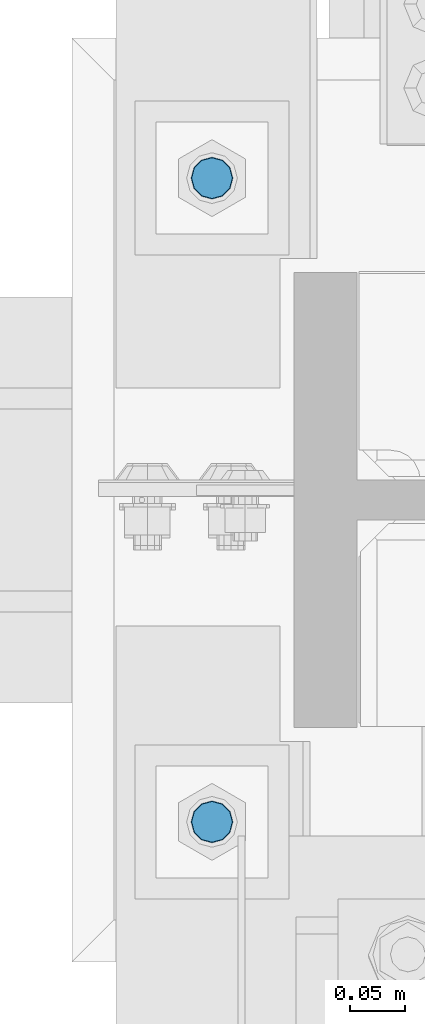
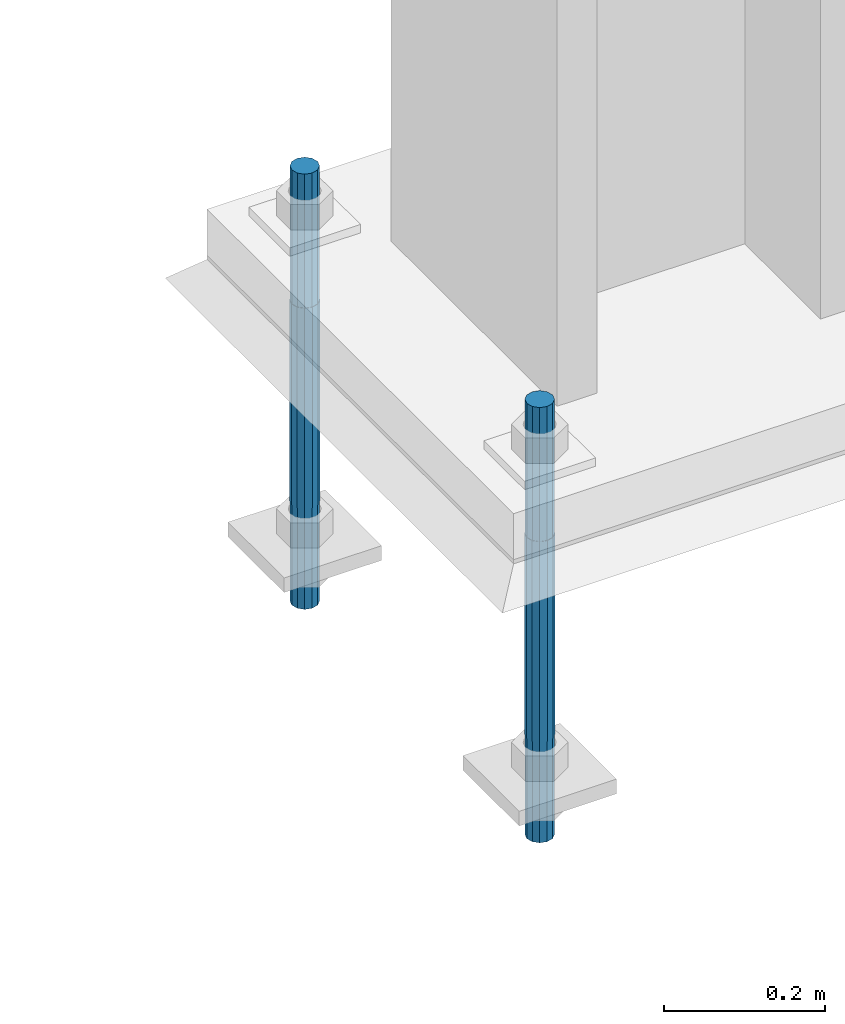
# One storey, part 1639 of 3843: 2 columns, 1 element without a shape of its own.
"""IFC2X3 building model written with IfcOpenShell, lengths in millimetres."""

from ifc_helpers import new_model, si_unit, frame, origin_with_axes, place, context, subcontext, project, spatial, faceted_brep, material, type_object, element, aggregate, save


model = new_model("IFC2X3")

# Units and contexts
model_context = context("Model", 3, precision=1e-05, world=origin_with_axes())
body_context = subcontext(model_context, "Body", "Model", "MODEL_VIEW")
ifc_project = project(units=[si_unit("LENGTHUNIT", "METRE", prefix="MILLI"), si_unit("AREAUNIT", "SQUARE_METRE"), si_unit("VOLUMEUNIT", "CUBIC_METRE"), si_unit("MASSUNIT", "GRAM", prefix="KILO"), si_unit("TIMEUNIT", "SECOND"), si_unit("PLANEANGLEUNIT", "RADIAN"), si_unit("SOLIDANGLEUNIT", "STERADIAN"), si_unit("THERMODYNAMICTEMPERATUREUNIT", "DEGREE_CELSIUS"), si_unit("LUMINOUSINTENSITYUNIT", "LUMEN")], contexts=[model_context])

# Site, building, storey
site_placement = place(None, origin_with_axes())
site = spatial("IfcSite", under=ifc_project, at=site_placement, CompositionType="ELEMENT")
building_placement = place(site_placement, origin_with_axes())
building = spatial("IfcBuilding", under=site, at=building_placement, Name="Undefined", CompositionType="ELEMENT")
storey_placement = place(building_placement, origin_with_axes())
storey = spatial("IfcBuildingStorey", under=building, at=storey_placement, Name="Undefined", CompositionType="ELEMENT", Elevation=0.0)

# Assembly, columns
assembly_placement = place(storey_placement, origin_with_axes())
assembly = element("IfcElementAssembly", 1, at=assembly_placement, inside=storey, Name="TEMPLATE", AssemblyPlace="NOTDEFINED", PredefinedType="RIGID_FRAME")
ifc_material = material(Name="Undefined/F1554-GR.55")
column_type = type_object("IfcColumnType", PredefinedType="NOTDEFINED")
column_1_placement = place(assembly_placement, frame((85356.7, 88823.8, 29565.6), z_axis=(1.0, 0.0, 0.0), x_axis=(0.0, 0.0, -1.0)))
column_1 = element("IfcColumn", 2, at=column_1_placement, type_object=column_type, material=ifc_material, Name="ANCHOR_ROD", context=body_context, shape_type="Brep", body=[
    faceted_brep([(-203.200000000001, -16.0214699700118, 9.25), (-203.200000000001, -9.25, 16.0214699700155), (-203.200000000001, 0.0, 18.5), (-203.200000000001, 9.25, 16.0214699700155), (-203.200000000001, 16.0214699700118, 9.25), (-203.200000000001, 18.5, 0.0), (-203.200000000001, 16.0214699700118, -9.25), (-203.200000000001, 9.25, -16.0214699700155), (-203.200000000001, 0.0, -18.5), (-203.200000000001, -9.25, -16.0214699700155), (-203.200000000001, -16.0214699700118, -9.25), (-203.200000000001, -18.5, 0.0), (0.0, 18.5, 0.0), (0.0, 16.0214699700118, -9.25), (0.0, 9.25, -16.0214699700155), (0.0, 0.0, -18.5), (0.0, -9.25, -16.0214699700155), (0.0, -16.0214699700118, -9.25), (0.0, -18.5, 0.0), (0.0, -16.0214699700118, 9.25), (0.0, -9.25, 16.0214699700155), (0.0, 0.0, 18.5), (0.0, 9.25, 16.0214699700155), (0.0, 16.0214699700118, 9.25), (0.0, -16.4977839420972, 9.52500000000146), (0.0, -9.52500000000146, 16.4977839420972), (0.0, 0.0, 19.0499989999989), (0.0, 9.52500000000146, 16.4977839420972), (0.0, 16.4977839420972, 9.52500000000146), (0.0, 19.0500000000029, 0.0), (0.0, 16.4977839420972, -9.52500000000146), (0.0, 9.52500000000146, -16.4977839420972), (0.0, 0.0, -19.0499989999989), (0.0, -9.52500000000146, -16.4977839420972), (0.0, -16.4977839420972, -9.52500000000146), (0.0, -19.0500000000029, 0.0), (304.799999999999, -19.0499999999993, 0.0), (304.799999999999, -16.4977839420935, 9.52499999999418), (304.799999999999, -9.52500000000146, 16.4977839420899), (304.799987999999, 0.0, 19.0499989999989), (304.799999999999, 9.52500000000146, 16.4977839420899), (304.799999999999, 16.4977839420935, 9.52499999999418), (304.799987792969, 19.0499999999993, 0.0), (304.799999999999, 16.4977839420935, -9.52499999999418), (304.799999999999, 9.52500000000146, -16.4977839420899), (304.799987999999, 0.0, -19.0499989999989), (304.799999999999, -9.52500000000146, -16.4977839420899), (304.799999999999, -16.4977839420935, -9.52499999999418), (304.799999999999, -9.25, 16.0214699700155), (304.799999999999, 0.0, 18.5), (304.799999999999, 9.25, 16.0214699700155), (304.799999999999, 16.0214699700118, 9.25), (304.799999999999, 18.5, 0.0), (304.799999999999, 16.0214699700118, -9.25), (304.799999999999, 9.25, -16.0214699700155), (304.799999999999, 0.0, -18.5), (304.799999999999, -9.25, -16.0214699700155), (304.799999999999, -16.0214699700118, -9.25), (304.799999999999, -18.5, 0.0), (304.799999999999, -16.0214699700118, 9.25), (457.200000000001, -9.25, -16.0214699700155), (457.200000000001, 0.0, -18.5), (457.200000000001, 9.25, -16.0214699700155), (457.200000000001, 16.0214699700118, -9.25), (457.200000000001, 18.5, 0.0), (457.200000000001, 16.0214699700118, 9.25), (457.200000000001, 9.25, 16.0214699700155), (457.200000000001, 0.0, 18.5), (457.200000000001, -9.25, 16.0214699700155), (457.200000000001, -16.0214699700118, 9.25), (457.200000000001, -18.5, 0.0), (457.200000000001, -16.0214699700118, -9.25)], [[[0, 1, 2, 3, 4, 5, 6, 7, 8, 9, 10, 11]], [[6, 5, 12, 13]], [[7, 6, 13, 14]], [[8, 7, 14, 15]], [[9, 8, 15, 16]], [[10, 9, 16, 17]], [[11, 10, 17, 18]], [[0, 11, 18, 19]], [[1, 0, 19, 20]], [[2, 1, 20, 21]], [[3, 2, 21, 22]], [[4, 3, 22, 23]], [[5, 4, 23, 12]], [[24, 25, 26, 27, 28, 29, 30, 31, 32, 33, 34, 35], [22, 21, 20, 19, 18, 17, 16, 15, 14, 13, 12, 23]], [[24, 35, 36, 37]], [[25, 24, 37, 38]], [[26, 25, 38, 39]], [[27, 26, 39, 40]], [[28, 27, 40, 41]], [[29, 28, 41, 42]], [[30, 29, 42, 43]], [[31, 30, 43, 44]], [[32, 31, 44, 45]], [[33, 32, 45, 46]], [[34, 33, 46, 47]], [[35, 34, 47, 36]], [[46, 45, 44, 43, 42, 41, 40, 39, 38, 37, 36, 47], [48, 49, 50, 51, 52, 53, 54, 55, 56, 57, 58, 59]], [[60, 61, 62, 63, 64, 65, 66, 67, 68, 69, 70, 71]], [[68, 67, 49, 48]], [[69, 68, 48, 59]], [[70, 69, 59, 58]], [[71, 70, 58, 57]], [[60, 71, 57, 56]], [[61, 60, 56, 55]], [[62, 61, 55, 54]], [[63, 62, 54, 53]], [[64, 63, 53, 52]], [[65, 64, 52, 51]], [[66, 65, 51, 50]], [[67, 66, 50, 49]]]),
])
column_2_placement = place(assembly_placement, frame((85356.7, 89408.0, 29565.6), z_axis=(-1.0, 0.0, 0.0), x_axis=(0.0, 0.0, -1.0)))
column_2 = element("IfcColumn", 3, at=column_2_placement, type_object=column_type, material=ifc_material, Name="ANCHOR_ROD", context=body_context, shape_type="Brep", body=[
    faceted_brep([(-203.200000000001, -16.0214699700118, 9.25), (-203.200000000001, -9.25, 16.0214699700155), (-203.200000000001, 0.0, 18.5), (-203.200000000001, 9.25, 16.0214699700155), (-203.200000000001, 16.0214699700118, 9.25), (-203.200000000001, 18.5, 0.0), (-203.200000000001, 16.0214699700118, -9.25), (-203.200000000001, 9.25, -16.0214699700155), (-203.200000000001, 0.0, -18.5), (-203.200000000001, -9.25, -16.0214699700155), (-203.200000000001, -16.0214699700118, -9.25), (-203.200000000001, -18.5, 0.0), (0.0, 18.5, 0.0), (0.0, 16.0214699700118, -9.25), (0.0, 9.25, -16.0214699700155), (0.0, 0.0, -18.5), (0.0, -9.25, -16.0214699700155), (0.0, -16.0214699700118, -9.25), (0.0, -18.5, 0.0), (0.0, -16.0214699700118, 9.25), (0.0, -9.25, 16.0214699700155), (0.0, 0.0, 18.5), (0.0, 9.25, 16.0214699700155), (0.0, 16.0214699700118, 9.25), (0.0, -16.4977839420972, 9.52500000000146), (0.0, -9.52500000000146, 16.4977839420972), (0.0, 0.0, 19.0499989999989), (0.0, 9.52500000000146, 16.4977839420972), (0.0, 16.4977839420972, 9.52500000000146), (0.0, 19.0500000000029, 0.0), (0.0, 16.4977839420972, -9.52500000000146), (0.0, 9.52500000000146, -16.4977839420972), (0.0, 0.0, -19.0499989999989), (0.0, -9.52500000000146, -16.4977839420972), (0.0, -16.4977839420972, -9.52500000000146), (0.0, -19.0500000000029, 0.0), (304.799999999999, -19.0499999999993, 0.0), (304.799999999999, -16.4977839420935, 9.52499999999418), (304.799999999999, -9.52500000000146, 16.4977839420899), (304.799987999999, 0.0, 19.0499989999989), (304.799999999999, 9.52500000000146, 16.4977839420899), (304.799999999999, 16.4977839420935, 9.52499999999418), (304.799987792969, 19.0499999999993, 0.0), (304.799999999999, 16.4977839420935, -9.52499999999418), (304.799999999999, 9.52500000000146, -16.4977839420899), (304.799987999999, 0.0, -19.0499989999989), (304.799999999999, -9.52500000000146, -16.4977839420899), (304.799999999999, -16.4977839420935, -9.52499999999418), (304.799999999999, -9.25, 16.0214699700155), (304.799999999999, 0.0, 18.5), (304.799999999999, 9.25, 16.0214699700155), (304.799999999999, 16.0214699700118, 9.25), (304.799999999999, 18.5, 0.0), (304.799999999999, 16.0214699700118, -9.25), (304.799999999999, 9.25, -16.0214699700155), (304.799999999999, 0.0, -18.5), (304.799999999999, -9.25, -16.0214699700155), (304.799999999999, -16.0214699700118, -9.25), (304.799999999999, -18.5, 0.0), (304.799999999999, -16.0214699700118, 9.25), (457.200000000001, -9.25, -16.0214699700155), (457.200000000001, 0.0, -18.5), (457.200000000001, 9.25, -16.0214699700155), (457.200000000001, 16.0214699700118, -9.25), (457.200000000001, 18.5, 0.0), (457.200000000001, 16.0214699700118, 9.25), (457.200000000001, 9.25, 16.0214699700155), (457.200000000001, 0.0, 18.5), (457.200000000001, -9.25, 16.0214699700155), (457.200000000001, -16.0214699700118, 9.25), (457.200000000001, -18.5, 0.0), (457.200000000001, -16.0214699700118, -9.25)], [[[0, 1, 2, 3, 4, 5, 6, 7, 8, 9, 10, 11]], [[6, 5, 12, 13]], [[7, 6, 13, 14]], [[8, 7, 14, 15]], [[9, 8, 15, 16]], [[10, 9, 16, 17]], [[11, 10, 17, 18]], [[0, 11, 18, 19]], [[1, 0, 19, 20]], [[2, 1, 20, 21]], [[3, 2, 21, 22]], [[4, 3, 22, 23]], [[5, 4, 23, 12]], [[24, 25, 26, 27, 28, 29, 30, 31, 32, 33, 34, 35], [22, 21, 20, 19, 18, 17, 16, 15, 14, 13, 12, 23]], [[24, 35, 36, 37]], [[25, 24, 37, 38]], [[26, 25, 38, 39]], [[27, 26, 39, 40]], [[28, 27, 40, 41]], [[29, 28, 41, 42]], [[30, 29, 42, 43]], [[31, 30, 43, 44]], [[32, 31, 44, 45]], [[33, 32, 45, 46]], [[34, 33, 46, 47]], [[35, 34, 47, 36]], [[46, 45, 44, 43, 42, 41, 40, 39, 38, 37, 36, 47], [48, 49, 50, 51, 52, 53, 54, 55, 56, 57, 58, 59]], [[60, 61, 62, 63, 64, 65, 66, 67, 68, 69, 70, 71]], [[68, 67, 49, 48]], [[69, 68, 48, 59]], [[70, 69, 59, 58]], [[71, 70, 58, 57]], [[60, 71, 57, 56]], [[61, 60, 56, 55]], [[62, 61, 55, 54]], [[63, 62, 54, 53]], [[64, 63, 53, 52]], [[65, 64, 52, 51]], [[66, 65, 51, 50]], [[67, 66, 50, 49]]]),
])
aggregate(assembly, [column_1, column_2])

save(model, "model.ifc")
